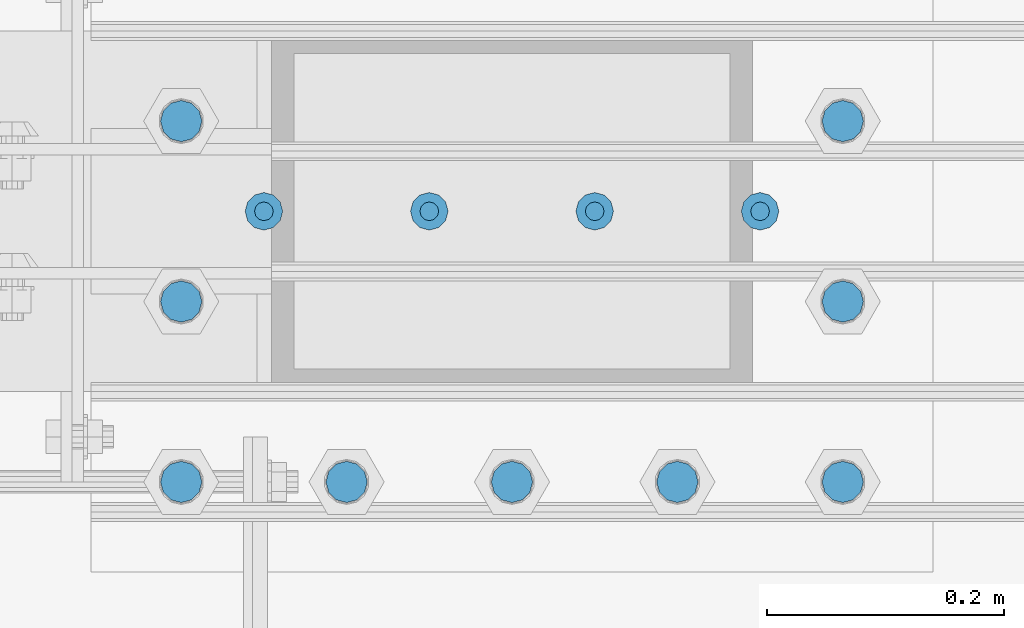
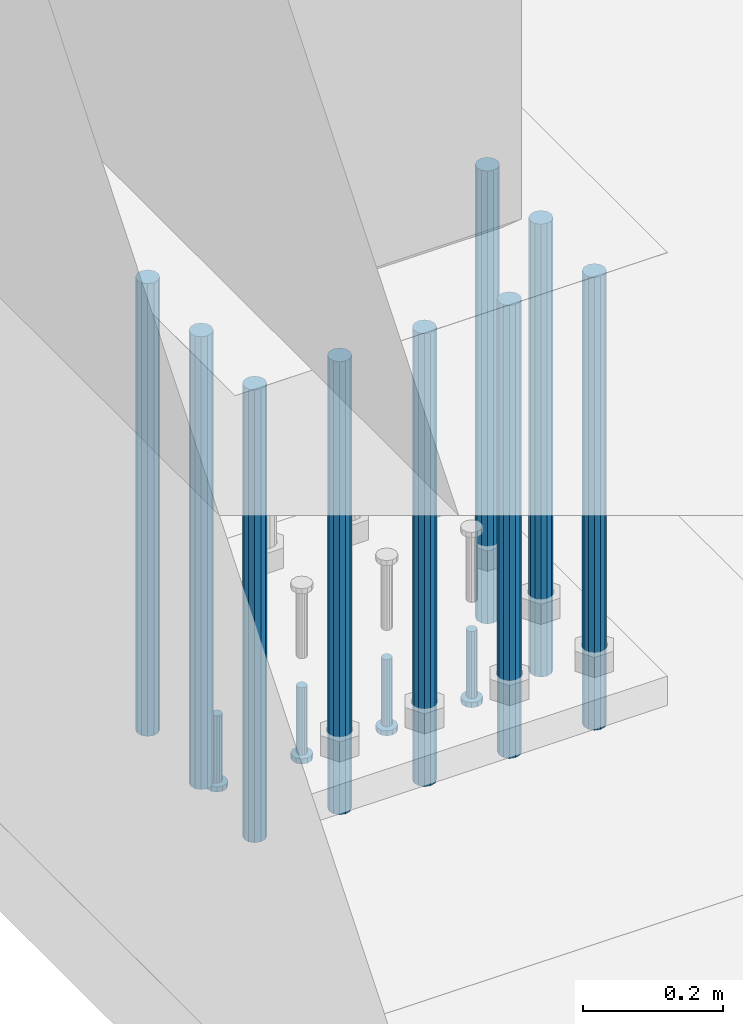
# One storey, part 1092 of 1876: 13 beams, 1 element without a shape of its own.
"""IFC2X3 building model written with IfcOpenShell, lengths in millimetres."""

from ifc_helpers import new_model, si_unit, frame, origin_with_axes, place, context, subcontext, project, spatial, faceted_brep, material, type_object, element, aggregate, save


model = new_model("IFC2X3")

# Units and contexts
model_context = context("Model", 3, precision=1e-05, world=origin_with_axes())
body_context = subcontext(model_context, "Body", "Model", "MODEL_VIEW")
ifc_project = project(units=[si_unit("LENGTHUNIT", "METRE", prefix="MILLI"), si_unit("AREAUNIT", "SQUARE_METRE"), si_unit("VOLUMEUNIT", "CUBIC_METRE"), si_unit("MASSUNIT", "GRAM", prefix="KILO"), si_unit("TIMEUNIT", "SECOND"), si_unit("PLANEANGLEUNIT", "RADIAN"), si_unit("SOLIDANGLEUNIT", "STERADIAN"), si_unit("THERMODYNAMICTEMPERATUREUNIT", "DEGREE_CELSIUS"), si_unit("LUMINOUSINTENSITYUNIT", "LUMEN")], contexts=[model_context])

# Site, building, storey
site_placement = place(None, origin_with_axes())
site = spatial("IfcSite", under=ifc_project, at=site_placement, CompositionType="ELEMENT")
building_placement = place(site_placement, origin_with_axes())
building = spatial("IfcBuilding", under=site, at=building_placement, Name="Undefined", CompositionType="ELEMENT")
storey_placement = place(building_placement, origin_with_axes())
storey = spatial("IfcBuildingStorey", under=building, at=storey_placement, Name="Undefined", CompositionType="ELEMENT", Elevation=0.0)

# Assembly, beams
assembly_placement = place(storey_placement, origin_with_axes())
assembly = element("IfcElementAssembly", 1, at=assembly_placement, inside=storey, Name="PLATE", AssemblyPlace="NOTDEFINED", PredefinedType="RIGID_FRAME")
ifc_material_1 = material(Name="STEEL/A108")
beam_type_1 = type_object("IfcBeamType", Name="5/8-DIA_HEADED ANCHOR STUD", PredefinedType="NOTDEFINED")
beam_1_placement = place(assembly_placement, frame((441.324993896483, -18084.8, -787.400000000001), z_axis=(1.0, 0.0, 0.0), x_axis=(0.0, 0.0, -1.0)))
beam_1 = element("IfcBeam", 2, at=beam_1_placement, type_object=beam_type_1, material=ifc_material_1, Name="HEADED ANCHOR STUD", ObjectType="5/8-DIA_HEADED ANCHOR STUD", context=body_context, shape_type="Brep", body=[
    faceted_brep([(0.0, -7.94000005722046, 0.0), (0.0, -6.86999988555908, -3.97000002861023), (116.84, -6.86999988555908, -3.97000002861023), (116.84, -7.94000005722046, 0.0), (0.0, -3.97000002861023, -6.86999988555908), (116.84, -3.97000002861023, -6.86999988555908), (0.0, 0.0, -7.94000005722046), (116.84, 0.0, -7.94000005722046), (0.0, 3.97000002861023, -6.86999988555908), (116.84, 3.97000002861023, -6.86999988555908), (0.0, 6.86999988555908, -3.97000002861023), (116.84, 6.86999988555908, -3.97000002861023), (0.0, 7.94000005722046, 0.0), (116.84, 7.94000005722046, 0.0), (0.0, 6.86999988555908, 3.97000002861023), (116.84, 6.86999988555908, 3.97000002861023), (0.0, 3.97000002861023, 6.86999988555908), (116.84, 3.97000002861023, 6.86999988555908), (0.0, 0.0, 7.94000005722046), (116.84, 0.0, 7.94000005722046), (0.0, -3.97000002861023, 6.86999988555908), (116.84, -3.97000002861023, 6.86999988555908), (0.0, -6.86999988555908, 3.97000002861023), (116.84, -6.86999988555908, 3.97000002861023), (118.11, -13.75, -7.94000005722046), (118.11, -15.8800001144409, 0.0), (118.11, -7.94000005722046, -13.75), (118.11, 0.0, -15.8800001144409), (118.11, 7.94000005722046, -13.75), (118.11, 13.75, -7.94000005722046), (118.11, 15.8800001144409, 0.0), (118.11, 13.75, 7.94000005722046), (118.11, 7.94000005722046, 13.75), (118.11, 0.0, 15.8800001144409), (118.11, -7.94000005722046, 13.75), (118.11, -13.75, 7.94000005722046), (127.0, -13.75, -7.94000005722046), (127.0, -15.8800001144409, 0.0), (127.0, -7.94000005722046, -13.75), (127.0, 0.0, -15.8800001144409), (127.0, 7.94000005722046, -13.75), (127.0, 13.75, -7.94000005722046), (127.0, 15.8800001144409, 0.0), (127.0, 13.75, 7.94000005722046), (127.0, 7.94000005722046, 13.75), (127.0, 0.0, 15.8800001144409), (127.0, -7.94000005722046, 13.75), (127.0, -13.75, 7.94000005722046)], [[[0, 1, 2, 3]], [[1, 4, 5, 2]], [[4, 6, 7, 5]], [[6, 8, 9, 7]], [[8, 10, 11, 9]], [[10, 12, 13, 11]], [[12, 14, 15, 13]], [[14, 16, 17, 15]], [[16, 18, 19, 17]], [[18, 20, 21, 19]], [[20, 22, 23, 21]], [[22, 0, 3, 23]], [[22, 20, 18, 16, 14, 12, 10, 8, 6, 4, 1, 0]], [[3, 2, 24, 25]], [[2, 5, 26, 24]], [[5, 7, 27, 26]], [[7, 9, 28, 27]], [[9, 11, 29, 28]], [[11, 13, 30, 29]], [[13, 15, 31, 30]], [[15, 17, 32, 31]], [[17, 19, 33, 32]], [[19, 21, 34, 33]], [[21, 23, 35, 34]], [[23, 3, 25, 35]], [[25, 24, 36, 37]], [[24, 26, 38, 36]], [[26, 27, 39, 38]], [[27, 28, 40, 39]], [[28, 29, 41, 40]], [[29, 30, 42, 41]], [[30, 31, 43, 42]], [[31, 32, 44, 43]], [[32, 33, 45, 44]], [[33, 34, 46, 45]], [[34, 35, 47, 46]], [[35, 25, 37, 47]], [[38, 39, 40, 41, 42, 43, 44, 45, 46, 47, 37, 36]]]),
])
beam_2_placement = place(assembly_placement, frame((301.624987792968, -18084.8, -787.400000000001), z_axis=(1.0, 0.0, 0.0), x_axis=(0.0, 0.0, -1.0)))
beam_2 = element("IfcBeam", 3, at=beam_2_placement, type_object=beam_type_1, material=ifc_material_1, Name="HEADED ANCHOR STUD", ObjectType="5/8-DIA_HEADED ANCHOR STUD", context=body_context, shape_type="Brep", body=[
    faceted_brep([(0.0, -7.94000005722046, 0.0), (0.0, -6.86999988555908, -3.97000002861023), (116.84, -6.86999988555908, -3.97000002861023), (116.84, -7.94000005722046, 0.0), (0.0, -3.97000002861023, -6.86999988555908), (116.84, -3.97000002861023, -6.86999988555908), (0.0, 0.0, -7.94000005722046), (116.84, 0.0, -7.94000005722046), (0.0, 3.97000002861023, -6.86999988555908), (116.84, 3.97000002861023, -6.86999988555908), (0.0, 6.86999988555908, -3.97000002861023), (116.84, 6.86999988555908, -3.97000002861023), (0.0, 7.94000005722046, 0.0), (116.84, 7.94000005722046, 0.0), (0.0, 6.86999988555908, 3.97000002861023), (116.84, 6.86999988555908, 3.97000002861023), (0.0, 3.97000002861023, 6.86999988555908), (116.84, 3.97000002861023, 6.86999988555908), (0.0, 0.0, 7.94000005722046), (116.84, 0.0, 7.94000005722046), (0.0, -3.97000002861023, 6.86999988555908), (116.84, -3.97000002861023, 6.86999988555908), (0.0, -6.86999988555908, 3.97000002861023), (116.84, -6.86999988555908, 3.97000002861023), (118.11, -13.75, -7.94000005722046), (118.11, -15.8800001144409, 0.0), (118.11, -7.94000005722046, -13.75), (118.11, 0.0, -15.8800001144409), (118.11, 7.94000005722046, -13.75), (118.11, 13.75, -7.94000005722046), (118.11, 15.8800001144409, 0.0), (118.11, 13.75, 7.94000005722046), (118.11, 7.94000005722046, 13.75), (118.11, 0.0, 15.8800001144409), (118.11, -7.94000005722046, 13.75), (118.11, -13.75, 7.94000005722046), (127.0, -13.75, -7.94000005722046), (127.0, -15.8800001144409, 0.0), (127.0, -7.94000005722046, -13.75), (127.0, 0.0, -15.8800001144409), (127.0, 7.94000005722046, -13.75), (127.0, 13.75, -7.94000005722046), (127.0, 15.8800001144409, 0.0), (127.0, 13.75, 7.94000005722046), (127.0, 7.94000005722046, 13.75), (127.0, 0.0, 15.8800001144409), (127.0, -7.94000005722046, 13.75), (127.0, -13.75, 7.94000005722046)], [[[0, 1, 2, 3]], [[1, 4, 5, 2]], [[4, 6, 7, 5]], [[6, 8, 9, 7]], [[8, 10, 11, 9]], [[10, 12, 13, 11]], [[12, 14, 15, 13]], [[14, 16, 17, 15]], [[16, 18, 19, 17]], [[18, 20, 21, 19]], [[20, 22, 23, 21]], [[22, 0, 3, 23]], [[22, 20, 18, 16, 14, 12, 10, 8, 6, 4, 1, 0]], [[3, 2, 24, 25]], [[2, 5, 26, 24]], [[5, 7, 27, 26]], [[7, 9, 28, 27]], [[9, 11, 29, 28]], [[11, 13, 30, 29]], [[13, 15, 31, 30]], [[15, 17, 32, 31]], [[17, 19, 33, 32]], [[19, 21, 34, 33]], [[21, 23, 35, 34]], [[23, 3, 25, 35]], [[25, 24, 36, 37]], [[24, 26, 38, 36]], [[26, 27, 39, 38]], [[27, 28, 40, 39]], [[28, 29, 41, 40]], [[29, 30, 42, 41]], [[30, 31, 43, 42]], [[31, 32, 44, 43]], [[32, 33, 45, 44]], [[33, 34, 46, 45]], [[34, 35, 47, 46]], [[35, 25, 37, 47]], [[38, 39, 40, 41, 42, 43, 44, 45, 46, 47, 37, 36]]]),
])
beam_3_placement = place(assembly_placement, frame((161.924987792968, -18084.8, -787.400000000001), z_axis=(1.0, 0.0, 0.0), x_axis=(0.0, 0.0, -1.0)))
beam_3 = element("IfcBeam", 4, at=beam_3_placement, type_object=beam_type_1, material=ifc_material_1, Name="HEADED ANCHOR STUD", ObjectType="5/8-DIA_HEADED ANCHOR STUD", context=body_context, shape_type="Brep", body=[
    faceted_brep([(0.0, -7.94000005722046, 0.0), (0.0, -6.86999988555908, -3.97000002861023), (116.84, -6.86999988555908, -3.97000002861023), (116.84, -7.94000005722046, 0.0), (0.0, -3.97000002861023, -6.86999988555908), (116.84, -3.97000002861023, -6.86999988555908), (0.0, 0.0, -7.94000005722046), (116.84, 0.0, -7.94000005722046), (0.0, 3.97000002861023, -6.86999988555908), (116.84, 3.97000002861023, -6.86999988555908), (0.0, 6.86999988555908, -3.97000002861023), (116.84, 6.86999988555908, -3.97000002861023), (0.0, 7.94000005722046, 0.0), (116.84, 7.94000005722046, 0.0), (0.0, 6.86999988555908, 3.97000002861023), (116.84, 6.86999988555908, 3.97000002861023), (0.0, 3.97000002861023, 6.86999988555908), (116.84, 3.97000002861023, 6.86999988555908), (0.0, 0.0, 7.94000005722046), (116.84, 0.0, 7.94000005722046), (0.0, -3.97000002861023, 6.86999988555908), (116.84, -3.97000002861023, 6.86999988555908), (0.0, -6.86999988555908, 3.97000002861023), (116.84, -6.86999988555908, 3.97000002861023), (118.11, -13.75, -7.94000005722046), (118.11, -15.8800001144409, 0.0), (118.11, -7.94000005722046, -13.75), (118.11, 0.0, -15.8800001144409), (118.11, 7.94000005722046, -13.75), (118.11, 13.75, -7.94000005722046), (118.11, 15.8800001144409, 0.0), (118.11, 13.75, 7.94000005722046), (118.11, 7.94000005722046, 13.75), (118.11, 0.0, 15.8800001144409), (118.11, -7.94000005722046, 13.75), (118.11, -13.75, 7.94000005722046), (127.0, -13.75, -7.94000005722046), (127.0, -15.8800001144409, 0.0), (127.0, -7.94000005722046, -13.75), (127.0, 0.0, -15.8800001144409), (127.0, 7.94000005722046, -13.75), (127.0, 13.75, -7.94000005722046), (127.0, 15.8800001144409, 0.0), (127.0, 13.75, 7.94000005722046), (127.0, 7.94000005722046, 13.75), (127.0, 0.0, 15.8800001144409), (127.0, -7.94000005722046, 13.75), (127.0, -13.75, 7.94000005722046)], [[[0, 1, 2, 3]], [[1, 4, 5, 2]], [[4, 6, 7, 5]], [[6, 8, 9, 7]], [[8, 10, 11, 9]], [[10, 12, 13, 11]], [[12, 14, 15, 13]], [[14, 16, 17, 15]], [[16, 18, 19, 17]], [[18, 20, 21, 19]], [[20, 22, 23, 21]], [[22, 0, 3, 23]], [[22, 20, 18, 16, 14, 12, 10, 8, 6, 4, 1, 0]], [[3, 2, 24, 25]], [[2, 5, 26, 24]], [[5, 7, 27, 26]], [[7, 9, 28, 27]], [[9, 11, 29, 28]], [[11, 13, 30, 29]], [[13, 15, 31, 30]], [[15, 17, 32, 31]], [[17, 19, 33, 32]], [[19, 21, 34, 33]], [[21, 23, 35, 34]], [[23, 3, 25, 35]], [[25, 24, 36, 37]], [[24, 26, 38, 36]], [[26, 27, 39, 38]], [[27, 28, 40, 39]], [[28, 29, 41, 40]], [[29, 30, 42, 41]], [[30, 31, 43, 42]], [[31, 32, 44, 43]], [[32, 33, 45, 44]], [[33, 34, 46, 45]], [[34, 35, 47, 46]], [[35, 25, 37, 47]], [[38, 39, 40, 41, 42, 43, 44, 45, 46, 47, 37, 36]]]),
])
beam_4_placement = place(assembly_placement, frame((22.2249877929677, -18084.8, -787.400000000001), z_axis=(1.0, 0.0, 0.0), x_axis=(0.0, 0.0, -1.0)))
beam_4 = element("IfcBeam", 5, at=beam_4_placement, type_object=beam_type_1, material=ifc_material_1, Name="HEADED ANCHOR STUD", ObjectType="5/8-DIA_HEADED ANCHOR STUD", context=body_context, shape_type="Brep", body=[
    faceted_brep([(0.0, -7.94000005722046, 0.0), (0.0, -6.86999988555908, -3.97000002861023), (116.84, -6.86999988555908, -3.97000002861023), (116.84, -7.94000005722046, 0.0), (0.0, -3.97000002861023, -6.86999988555908), (116.84, -3.97000002861023, -6.86999988555908), (0.0, 0.0, -7.94000005722046), (116.84, 0.0, -7.94000005722046), (0.0, 3.97000002861023, -6.86999988555908), (116.84, 3.97000002861023, -6.86999988555908), (0.0, 6.86999988555908, -3.97000002861023), (116.84, 6.86999988555908, -3.97000002861023), (0.0, 7.94000005722046, 0.0), (116.84, 7.94000005722046, 0.0), (0.0, 6.86999988555908, 3.97000002861023), (116.84, 6.86999988555908, 3.97000002861023), (0.0, 3.97000002861023, 6.86999988555908), (116.84, 3.97000002861023, 6.86999988555908), (0.0, 0.0, 7.94000005722046), (116.84, 0.0, 7.94000005722046), (0.0, -3.97000002861023, 6.86999988555908), (116.84, -3.97000002861023, 6.86999988555908), (0.0, -6.86999988555908, 3.97000002861023), (116.84, -6.86999988555908, 3.97000002861023), (118.11, -13.75, -7.94000005722046), (118.11, -15.8800001144409, 0.0), (118.11, -7.94000005722046, -13.75), (118.11, 0.0, -15.8800001144409), (118.11, 7.94000005722046, -13.75), (118.11, 13.75, -7.94000005722046), (118.11, 15.8800001144409, 0.0), (118.11, 13.75, 7.94000005722046), (118.11, 7.94000005722046, 13.75), (118.11, 0.0, 15.8800001144409), (118.11, -7.94000005722046, 13.75), (118.11, -13.75, 7.94000005722046), (127.0, -13.75, -7.94000005722046), (127.0, -15.8800001144409, 0.0), (127.0, -7.94000005722046, -13.75), (127.0, 0.0, -15.8800001144409), (127.0, 7.94000005722046, -13.75), (127.0, 13.75, -7.94000005722046), (127.0, 15.8800001144409, 0.0), (127.0, 13.75, 7.94000005722046), (127.0, 7.94000005722046, 13.75), (127.0, 0.0, 15.8800001144409), (127.0, -7.94000005722046, 13.75), (127.0, -13.75, 7.94000005722046)], [[[0, 1, 2, 3]], [[1, 4, 5, 2]], [[4, 6, 7, 5]], [[6, 8, 9, 7]], [[8, 10, 11, 9]], [[10, 12, 13, 11]], [[12, 14, 15, 13]], [[14, 16, 17, 15]], [[16, 18, 19, 17]], [[18, 20, 21, 19]], [[20, 22, 23, 21]], [[22, 0, 3, 23]], [[22, 20, 18, 16, 14, 12, 10, 8, 6, 4, 1, 0]], [[3, 2, 24, 25]], [[2, 5, 26, 24]], [[5, 7, 27, 26]], [[7, 9, 28, 27]], [[9, 11, 29, 28]], [[11, 13, 30, 29]], [[13, 15, 31, 30]], [[15, 17, 32, 31]], [[17, 19, 33, 32]], [[19, 21, 34, 33]], [[21, 23, 35, 34]], [[23, 3, 25, 35]], [[25, 24, 36, 37]], [[24, 26, 38, 36]], [[26, 27, 39, 38]], [[27, 28, 40, 39]], [[28, 29, 41, 40]], [[29, 30, 42, 41]], [[30, 31, 43, 42]], [[31, 32, 44, 43]], [[32, 33, 45, 44]], [[33, 34, 46, 45]], [[34, 35, 47, 46]], [[35, 25, 37, 47]], [[38, 39, 40, 41, 42, 43, 44, 45, 46, 47, 37, 36]]]),
])
ifc_material_2 = material(Name="STEEL/F1554-55, S1")
beam_type_2 = type_object("IfcBeamType", PredefinedType="NOTDEFINED")
beam_5_placement = place(assembly_placement, frame((371.474987792968, -18313.3999755859, -50.7999999999993), z_axis=(0.0, -1.0, 0.0), x_axis=(0.0, 0.0, -1.0)))
beam_5 = element("IfcBeam", 6, at=beam_5_placement, type_object=beam_type_2, material=ifc_material_2, Name="WELDED HEADED STUD", context=body_context, shape_type="Brep", body=[
    faceted_brep([(0.0, -17.4625, 0.0), (0.0, -15.1229686135857, -8.73125000000073), (787.399999999999, -15.1229686135857, -8.73125000000073), (787.399999999999, -17.4625, 0.0), (0.0, -8.73124999999999, -15.1229686135848), (787.399999999999, -8.73124999999999, -15.1229686135848), (0.0, 0.0, -17.4625000000015), (787.399999999999, 0.0, -17.4625000000015), (0.0, 8.73124999999999, -15.1229686135848), (787.399999999999, 8.73124999999999, -15.1229686135848), (0.0, 15.1229686135858, -8.73125000000073), (787.399999999999, 15.1229686135858, -8.73125000000073), (0.0, 17.4625, 0.0), (787.399999999999, 17.4625, 0.0), (0.0, 15.1229686135858, 8.73125000000073), (787.399999999999, 15.1229686135858, 8.73125000000073), (0.0, 8.73124999999999, 15.1229686135848), (787.399999999999, 8.73124999999999, 15.1229686135848), (0.0, 0.0, 17.4625000000015), (787.399999999999, 0.0, 17.4625000000015), (0.0, -8.73124999999999, 15.1229686135848), (787.399999999999, -8.73124999999999, 15.1229686135848), (0.0, -15.1229686135858, 8.73125000000073), (787.399999999999, -15.1229686135858, 8.73125000000073)], [[[0, 1, 2, 3]], [[1, 4, 5, 2]], [[4, 6, 7, 5]], [[6, 8, 9, 7]], [[8, 10, 11, 9]], [[10, 12, 13, 11]], [[12, 14, 15, 13]], [[14, 16, 17, 15]], [[16, 18, 19, 17]], [[18, 20, 21, 19]], [[20, 22, 23, 21]], [[22, 0, 3, 23]], [[5, 7, 9, 11, 13, 15, 17, 19, 21, 23, 3, 2]], [[22, 20, 18, 16, 14, 12, 10, 8, 6, 4, 1, 0]]]),
])
beam_6_placement = place(assembly_placement, frame((231.774987792968, -18313.3999755859, -50.7999999999993), z_axis=(0.0, -1.0, 0.0), x_axis=(0.0, 0.0, -1.0)))
beam_6 = element("IfcBeam", 7, at=beam_6_placement, type_object=beam_type_2, material=ifc_material_2, Name="WELDED HEADED STUD", context=body_context, shape_type="Brep", body=[
    faceted_brep([(0.0, -17.4625, 0.0), (0.0, -15.1229686135857, -8.73125000000073), (787.399999999999, -15.1229686135857, -8.73125000000073), (787.399999999999, -17.4625, 0.0), (0.0, -8.73124999999999, -15.1229686135848), (787.399999999999, -8.73124999999999, -15.1229686135848), (0.0, 0.0, -17.4625000000015), (787.399999999999, 0.0, -17.4625000000015), (0.0, 8.73124999999999, -15.1229686135848), (787.399999999999, 8.73124999999999, -15.1229686135848), (0.0, 15.1229686135858, -8.73125000000073), (787.399999999999, 15.1229686135858, -8.73125000000073), (0.0, 17.4625, 0.0), (787.399999999999, 17.4625, 0.0), (0.0, 15.1229686135858, 8.73125000000073), (787.399999999999, 15.1229686135858, 8.73125000000073), (0.0, 8.73124999999999, 15.1229686135848), (787.399999999999, 8.73124999999999, 15.1229686135848), (0.0, 0.0, 17.4625000000015), (787.399999999999, 0.0, 17.4625000000015), (0.0, -8.73124999999999, 15.1229686135848), (787.399999999999, -8.73124999999999, 15.1229686135848), (0.0, -15.1229686135858, 8.73125000000073), (787.399999999999, -15.1229686135858, 8.73125000000073)], [[[0, 1, 2, 3]], [[1, 4, 5, 2]], [[4, 6, 7, 5]], [[6, 8, 9, 7]], [[8, 10, 11, 9]], [[10, 12, 13, 11]], [[12, 14, 15, 13]], [[14, 16, 17, 15]], [[16, 18, 19, 17]], [[18, 20, 21, 19]], [[20, 22, 23, 21]], [[22, 0, 3, 23]], [[5, 7, 9, 11, 13, 15, 17, 19, 21, 23, 3, 2]], [[22, 20, 18, 16, 14, 12, 10, 8, 6, 4, 1, 0]]]),
])
beam_7_placement = place(assembly_placement, frame((92.0749877929678, -18313.3999755859, -50.7999999999993), z_axis=(0.0, -1.0, 0.0), x_axis=(0.0, 0.0, -1.0)))
beam_7 = element("IfcBeam", 8, at=beam_7_placement, type_object=beam_type_2, material=ifc_material_2, Name="WELDED HEADED STUD", context=body_context, shape_type="Brep", body=[
    faceted_brep([(0.0, -17.4625, 0.0), (0.0, -15.1229686135857, -8.73125000000073), (787.399999999999, -15.1229686135857, -8.73125000000073), (787.399999999999, -17.4625, 0.0), (0.0, -8.73124999999999, -15.1229686135848), (787.399999999999, -8.73124999999999, -15.1229686135848), (0.0, 0.0, -17.4625000000015), (787.399999999999, 0.0, -17.4625000000015), (0.0, 8.73124999999999, -15.1229686135848), (787.399999999999, 8.73124999999999, -15.1229686135848), (0.0, 15.1229686135858, -8.73125000000073), (787.399999999999, 15.1229686135858, -8.73125000000073), (0.0, 17.4625, 0.0), (787.399999999999, 17.4625, 0.0), (0.0, 15.1229686135858, 8.73125000000073), (787.399999999999, 15.1229686135858, 8.73125000000073), (0.0, 8.73124999999999, 15.1229686135848), (787.399999999999, 8.73124999999999, 15.1229686135848), (0.0, 0.0, 17.4625000000015), (787.399999999999, 0.0, 17.4625000000015), (0.0, -8.73124999999999, 15.1229686135848), (787.399999999999, -8.73124999999999, 15.1229686135848), (0.0, -15.1229686135858, 8.73125000000073), (787.399999999999, -15.1229686135858, 8.73125000000073)], [[[0, 1, 2, 3]], [[1, 4, 5, 2]], [[4, 6, 7, 5]], [[6, 8, 9, 7]], [[8, 10, 11, 9]], [[10, 12, 13, 11]], [[12, 14, 15, 13]], [[14, 16, 17, 15]], [[16, 18, 19, 17]], [[18, 20, 21, 19]], [[20, 22, 23, 21]], [[22, 0, 3, 23]], [[5, 7, 9, 11, 13, 15, 17, 19, 21, 23, 3, 2]], [[22, 20, 18, 16, 14, 12, 10, 8, 6, 4, 1, 0]]]),
])
beam_8_placement = place(assembly_placement, frame((-47.6250122070323, -18008.599991862, -50.7999999999993), z_axis=(0.0, -1.0, 0.0), x_axis=(0.0, 0.0, -1.0)))
beam_8 = element("IfcBeam", 9, at=beam_8_placement, type_object=beam_type_2, material=ifc_material_2, Name="WELDED HEADED STUD", context=body_context, shape_type="Brep", body=[
    faceted_brep([(0.0, -17.4625, 0.0), (0.0, -15.1229686135857, -8.73125000000073), (787.399999999999, -15.1229686135857, -8.73125000000073), (787.399999999999, -17.4625, 0.0), (0.0, -8.73124999999999, -15.1229686135848), (787.399999999999, -8.73124999999999, -15.1229686135848), (0.0, 0.0, -17.4625000000015), (787.399999999999, 0.0, -17.4625000000015), (0.0, 8.73124999999999, -15.1229686135848), (787.399999999999, 8.73124999999999, -15.1229686135848), (0.0, 15.1229686135858, -8.73125000000073), (787.399999999999, 15.1229686135858, -8.73125000000073), (0.0, 17.4625, 0.0), (787.399999999999, 17.4625, 0.0), (0.0, 15.1229686135858, 8.73125000000073), (787.399999999999, 15.1229686135858, 8.73125000000073), (0.0, 8.73124999999999, 15.1229686135848), (787.399999999999, 8.73124999999999, 15.1229686135848), (0.0, 0.0, 17.4625000000015), (787.399999999999, 0.0, 17.4625000000015), (0.0, -8.73124999999999, 15.1229686135848), (787.399999999999, -8.73124999999999, 15.1229686135848), (0.0, -15.1229686135858, 8.73125000000073), (787.399999999999, -15.1229686135858, 8.73125000000073)], [[[0, 1, 2, 3]], [[1, 4, 5, 2]], [[4, 6, 7, 5]], [[6, 8, 9, 7]], [[8, 10, 11, 9]], [[10, 12, 13, 11]], [[12, 14, 15, 13]], [[14, 16, 17, 15]], [[16, 18, 19, 17]], [[18, 20, 21, 19]], [[20, 22, 23, 21]], [[22, 0, 3, 23]], [[5, 7, 9, 11, 13, 15, 17, 19, 21, 23, 3, 2]], [[22, 20, 18, 16, 14, 12, 10, 8, 6, 4, 1, 0]]]),
])
beam_9_placement = place(assembly_placement, frame((-47.6250122070322, -18160.999983724, -50.7999999999993), z_axis=(0.0, -1.0, 0.0), x_axis=(0.0, 0.0, -1.0)))
beam_9 = element("IfcBeam", 10, at=beam_9_placement, type_object=beam_type_2, material=ifc_material_2, Name="WELDED HEADED STUD", context=body_context, shape_type="Brep", body=[
    faceted_brep([(0.0, -17.4625, 0.0), (0.0, -15.1229686135857, -8.73125000000073), (787.399999999999, -15.1229686135857, -8.73125000000073), (787.399999999999, -17.4625, 0.0), (0.0, -8.73124999999999, -15.1229686135848), (787.399999999999, -8.73124999999999, -15.1229686135848), (0.0, 0.0, -17.4625000000015), (787.399999999999, 0.0, -17.4625000000015), (0.0, 8.73124999999999, -15.1229686135848), (787.399999999999, 8.73124999999999, -15.1229686135848), (0.0, 15.1229686135858, -8.73125000000073), (787.399999999999, 15.1229686135858, -8.73125000000073), (0.0, 17.4625, 0.0), (787.399999999999, 17.4625, 0.0), (0.0, 15.1229686135858, 8.73125000000073), (787.399999999999, 15.1229686135858, 8.73125000000073), (0.0, 8.73124999999999, 15.1229686135848), (787.399999999999, 8.73124999999999, 15.1229686135848), (0.0, 0.0, 17.4625000000015), (787.399999999999, 0.0, 17.4625000000015), (0.0, -8.73124999999999, 15.1229686135848), (787.399999999999, -8.73124999999999, 15.1229686135848), (0.0, -15.1229686135858, 8.73125000000073), (787.399999999999, -15.1229686135858, 8.73125000000073)], [[[0, 1, 2, 3]], [[1, 4, 5, 2]], [[4, 6, 7, 5]], [[6, 8, 9, 7]], [[8, 10, 11, 9]], [[10, 12, 13, 11]], [[12, 14, 15, 13]], [[14, 16, 17, 15]], [[16, 18, 19, 17]], [[18, 20, 21, 19]], [[20, 22, 23, 21]], [[22, 0, 3, 23]], [[5, 7, 9, 11, 13, 15, 17, 19, 21, 23, 3, 2]], [[22, 20, 18, 16, 14, 12, 10, 8, 6, 4, 1, 0]]]),
])
beam_10_placement = place(assembly_placement, frame((-47.6250122070322, -18313.3999755859, -50.7999999999993), z_axis=(0.0, -1.0, 0.0), x_axis=(0.0, 0.0, -1.0)))
beam_10 = element("IfcBeam", 11, at=beam_10_placement, type_object=beam_type_2, material=ifc_material_2, Name="WELDED HEADED STUD", context=body_context, shape_type="Brep", body=[
    faceted_brep([(0.0, -17.4625, 0.0), (0.0, -15.1229686135857, -8.73125000000073), (787.399999999999, -15.1229686135857, -8.73125000000073), (787.399999999999, -17.4625, 0.0), (0.0, -8.73124999999999, -15.1229686135848), (787.399999999999, -8.73124999999999, -15.1229686135848), (0.0, 0.0, -17.4625000000015), (787.399999999999, 0.0, -17.4625000000015), (0.0, 8.73124999999999, -15.1229686135848), (787.399999999999, 8.73124999999999, -15.1229686135848), (0.0, 15.1229686135858, -8.73125000000073), (787.399999999999, 15.1229686135858, -8.73125000000073), (0.0, 17.4625, 0.0), (787.399999999999, 17.4625, 0.0), (0.0, 15.1229686135858, 8.73125000000073), (787.399999999999, 15.1229686135858, 8.73125000000073), (0.0, 8.73124999999999, 15.1229686135848), (787.399999999999, 8.73124999999999, 15.1229686135848), (0.0, 0.0, 17.4625000000015), (787.399999999999, 0.0, 17.4625000000015), (0.0, -8.73124999999999, 15.1229686135848), (787.399999999999, -8.73124999999999, 15.1229686135848), (0.0, -15.1229686135858, 8.73125000000073), (787.399999999999, -15.1229686135858, 8.73125000000073)], [[[0, 1, 2, 3]], [[1, 4, 5, 2]], [[4, 6, 7, 5]], [[6, 8, 9, 7]], [[8, 10, 11, 9]], [[10, 12, 13, 11]], [[12, 14, 15, 13]], [[14, 16, 17, 15]], [[16, 18, 19, 17]], [[18, 20, 21, 19]], [[20, 22, 23, 21]], [[22, 0, 3, 23]], [[5, 7, 9, 11, 13, 15, 17, 19, 21, 23, 3, 2]], [[22, 20, 18, 16, 14, 12, 10, 8, 6, 4, 1, 0]]]),
])
beam_11_placement = place(assembly_placement, frame((511.174999999999, -18008.599991862, -50.7999999999993), z_axis=(0.0, -1.0, 0.0), x_axis=(0.0, 0.0, -1.0)))
beam_11 = element("IfcBeam", 12, at=beam_11_placement, type_object=beam_type_2, material=ifc_material_2, Name="WELDED HEADED STUD", context=body_context, shape_type="Brep", body=[
    faceted_brep([(0.0, -17.4625, 0.0), (0.0, -15.1229686135857, -8.73125000000073), (787.399999999999, -15.1229686135857, -8.73125000000073), (787.399999999999, -17.4625, 0.0), (0.0, -8.73124999999999, -15.1229686135848), (787.399999999999, -8.73124999999999, -15.1229686135848), (0.0, 0.0, -17.4625000000015), (787.399999999999, 0.0, -17.4625000000015), (0.0, 8.73124999999999, -15.1229686135848), (787.399999999999, 8.73124999999999, -15.1229686135848), (0.0, 15.1229686135858, -8.73125000000073), (787.399999999999, 15.1229686135858, -8.73125000000073), (0.0, 17.4625, 0.0), (787.399999999999, 17.4625, 0.0), (0.0, 15.1229686135858, 8.73125000000073), (787.399999999999, 15.1229686135858, 8.73125000000073), (0.0, 8.73124999999999, 15.1229686135848), (787.399999999999, 8.73124999999999, 15.1229686135848), (0.0, 0.0, 17.4625000000015), (787.399999999999, 0.0, 17.4625000000015), (0.0, -8.73124999999999, 15.1229686135848), (787.399999999999, -8.73124999999999, 15.1229686135848), (0.0, -15.1229686135858, 8.73125000000073), (787.399999999999, -15.1229686135858, 8.73125000000073)], [[[0, 1, 2, 3]], [[1, 4, 5, 2]], [[4, 6, 7, 5]], [[6, 8, 9, 7]], [[8, 10, 11, 9]], [[10, 12, 13, 11]], [[12, 14, 15, 13]], [[14, 16, 17, 15]], [[16, 18, 19, 17]], [[18, 20, 21, 19]], [[20, 22, 23, 21]], [[22, 0, 3, 23]], [[5, 7, 9, 11, 13, 15, 17, 19, 21, 23, 3, 2]], [[22, 20, 18, 16, 14, 12, 10, 8, 6, 4, 1, 0]]]),
])
beam_12_placement = place(assembly_placement, frame((511.174999999999, -18160.999983724, -50.7999999999993), z_axis=(0.0, -1.0, 0.0), x_axis=(0.0, 0.0, -1.0)))
beam_12 = element("IfcBeam", 13, at=beam_12_placement, type_object=beam_type_2, material=ifc_material_2, Name="WELDED HEADED STUD", context=body_context, shape_type="Brep", body=[
    faceted_brep([(0.0, -17.4625, 0.0), (0.0, -15.1229686135857, -8.73125000000073), (787.399999999999, -15.1229686135857, -8.73125000000073), (787.399999999999, -17.4625, 0.0), (0.0, -8.73124999999999, -15.1229686135848), (787.399999999999, -8.73124999999999, -15.1229686135848), (0.0, 0.0, -17.4625000000015), (787.399999999999, 0.0, -17.4625000000015), (0.0, 8.73124999999999, -15.1229686135848), (787.399999999999, 8.73124999999999, -15.1229686135848), (0.0, 15.1229686135858, -8.73125000000073), (787.399999999999, 15.1229686135858, -8.73125000000073), (0.0, 17.4625, 0.0), (787.399999999999, 17.4625, 0.0), (0.0, 15.1229686135858, 8.73125000000073), (787.399999999999, 15.1229686135858, 8.73125000000073), (0.0, 8.73124999999999, 15.1229686135848), (787.399999999999, 8.73124999999999, 15.1229686135848), (0.0, 0.0, 17.4625000000015), (787.399999999999, 0.0, 17.4625000000015), (0.0, -8.73124999999999, 15.1229686135848), (787.399999999999, -8.73124999999999, 15.1229686135848), (0.0, -15.1229686135858, 8.73125000000073), (787.399999999999, -15.1229686135858, 8.73125000000073)], [[[0, 1, 2, 3]], [[1, 4, 5, 2]], [[4, 6, 7, 5]], [[6, 8, 9, 7]], [[8, 10, 11, 9]], [[10, 12, 13, 11]], [[12, 14, 15, 13]], [[14, 16, 17, 15]], [[16, 18, 19, 17]], [[18, 20, 21, 19]], [[20, 22, 23, 21]], [[22, 0, 3, 23]], [[5, 7, 9, 11, 13, 15, 17, 19, 21, 23, 3, 2]], [[22, 20, 18, 16, 14, 12, 10, 8, 6, 4, 1, 0]]]),
])
beam_13_placement = place(assembly_placement, frame((511.174999999999, -18313.3999755859, -50.7999999999993), z_axis=(0.0, -1.0, 0.0), x_axis=(0.0, 0.0, -1.0)))
beam_13 = element("IfcBeam", 14, at=beam_13_placement, type_object=beam_type_2, material=ifc_material_2, Name="WELDED HEADED STUD", context=body_context, shape_type="Brep", body=[
    faceted_brep([(0.0, -17.4625, 0.0), (0.0, -15.1229686135857, -8.73125000000073), (787.399999999999, -15.1229686135857, -8.73125000000073), (787.399999999999, -17.4625, 0.0), (0.0, -8.73124999999999, -15.1229686135848), (787.399999999999, -8.73124999999999, -15.1229686135848), (0.0, 0.0, -17.4625000000015), (787.399999999999, 0.0, -17.4625000000015), (0.0, 8.73124999999999, -15.1229686135848), (787.399999999999, 8.73124999999999, -15.1229686135848), (0.0, 15.1229686135858, -8.73125000000073), (787.399999999999, 15.1229686135858, -8.73125000000073), (0.0, 17.4625, 0.0), (787.399999999999, 17.4625, 0.0), (0.0, 15.1229686135858, 8.73125000000073), (787.399999999999, 15.1229686135858, 8.73125000000073), (0.0, 8.73124999999999, 15.1229686135848), (787.399999999999, 8.73124999999999, 15.1229686135848), (0.0, 0.0, 17.4625000000015), (787.399999999999, 0.0, 17.4625000000015), (0.0, -8.73124999999999, 15.1229686135848), (787.399999999999, -8.73124999999999, 15.1229686135848), (0.0, -15.1229686135858, 8.73125000000073), (787.399999999999, -15.1229686135858, 8.73125000000073)], [[[0, 1, 2, 3]], [[1, 4, 5, 2]], [[4, 6, 7, 5]], [[6, 8, 9, 7]], [[8, 10, 11, 9]], [[10, 12, 13, 11]], [[12, 14, 15, 13]], [[14, 16, 17, 15]], [[16, 18, 19, 17]], [[18, 20, 21, 19]], [[20, 22, 23, 21]], [[22, 0, 3, 23]], [[5, 7, 9, 11, 13, 15, 17, 19, 21, 23, 3, 2]], [[22, 20, 18, 16, 14, 12, 10, 8, 6, 4, 1, 0]]]),
])
aggregate(assembly, [beam_1, beam_2, beam_3, beam_4, beam_5, beam_6, beam_7, beam_8, beam_9, beam_10, beam_11, beam_12, beam_13])

save(model, "model.ifc")
